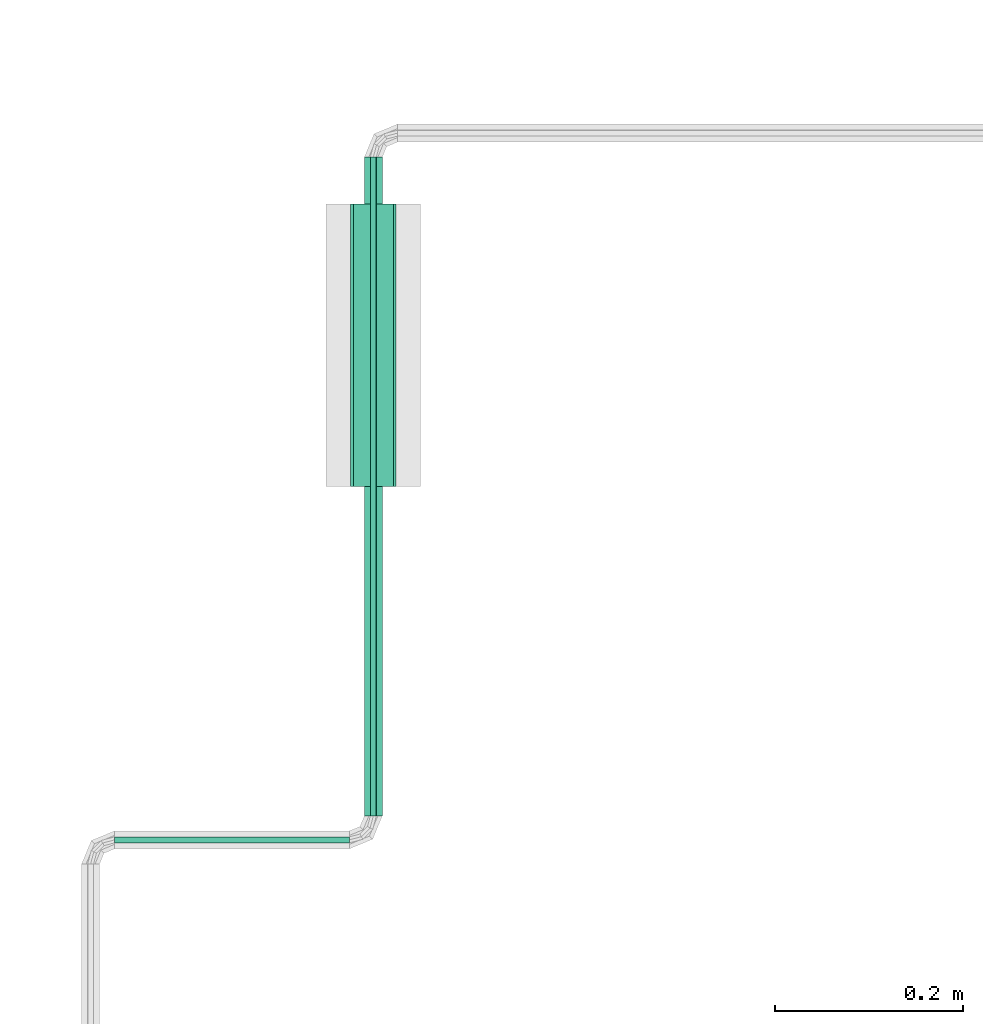
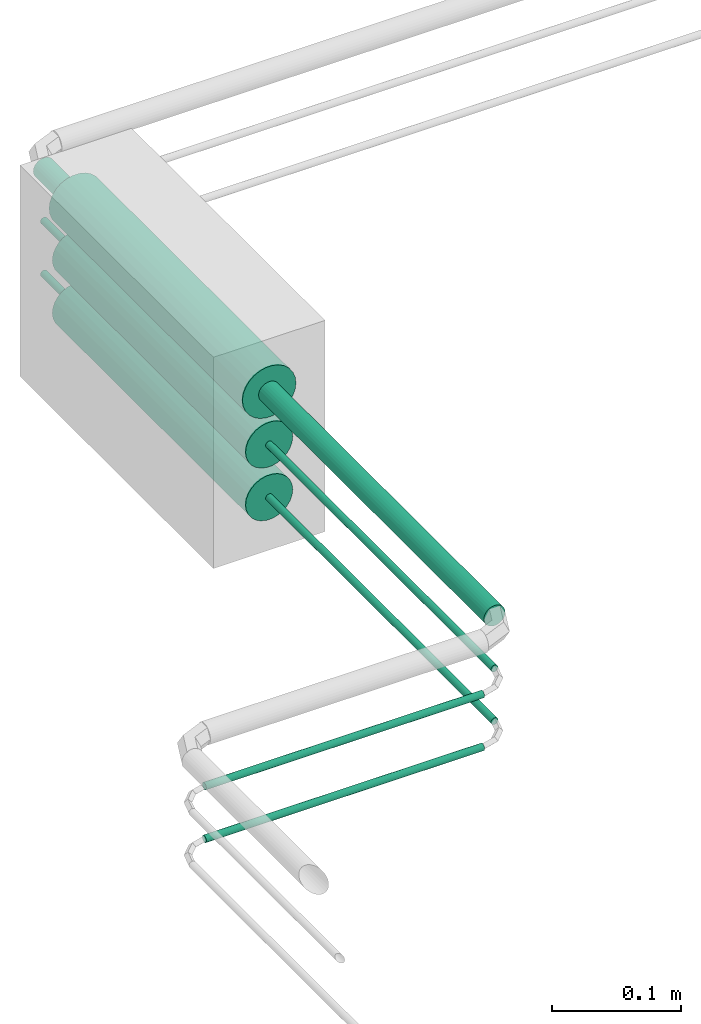
# One storey, part 17 of 45: 8 flow segments.
"""IFC2X3 building model written with IfcOpenShell, lengths in millimetres."""

from ifc_helpers import new_model, entity, si_unit, converted_unit, derived_unit, direction, frame, origin, origin_2d_with_axis, place, context, subcontext, project, spatial, circle, extrude, type_object, element, save


model = new_model("IFC2X3")

# Units and contexts
model_context = context("Model", 3, precision=0.01, world=origin(), true_north=direction((6.12303176911189e-17, 1.0)))
body_context = subcontext(model_context, "Body", "Model", "MODEL_VIEW")
ifc_project = project(units=[si_unit("LENGTHUNIT", "METRE", prefix="MILLI"), si_unit("AREAUNIT", "SQUARE_METRE"), si_unit("VOLUMEUNIT", "CUBIC_METRE"), converted_unit("PLANEANGLEUNIT", "DEGREE", entity("IfcRatioMeasure", 0.0174532925199433), si_unit("PLANEANGLEUNIT", "RADIAN"), dimensions=[0, 0, 0, 0, 0, 0, 0]), si_unit("MASSUNIT", "GRAM", prefix="KILO"), derived_unit("MASSDENSITYUNIT", [(si_unit("MASSUNIT", "GRAM", prefix="KILO"), 1), (si_unit("LENGTHUNIT", "METRE"), -3)]), derived_unit("MOMENTOFINERTIAUNIT", [(si_unit("LENGTHUNIT", "METRE"), 4)]), si_unit("TIMEUNIT", "SECOND"), si_unit("FREQUENCYUNIT", "HERTZ"), si_unit("THERMODYNAMICTEMPERATUREUNIT", "DEGREE_CELSIUS"), derived_unit("THERMALTRANSMITTANCEUNIT", [(si_unit("MASSUNIT", "GRAM", prefix="KILO"), 1), (si_unit("THERMODYNAMICTEMPERATUREUNIT", "KELVIN"), -1), (si_unit("TIMEUNIT", "SECOND"), -3)]), derived_unit("VOLUMETRICFLOWRATEUNIT", [(si_unit("LENGTHUNIT", "METRE"), 3), (si_unit("TIMEUNIT", "SECOND"), -1)]), derived_unit("MASSFLOWRATEUNIT", [(si_unit("MASSUNIT", "GRAM", prefix="KILO"), 1), (si_unit("TIMEUNIT", "SECOND"), -1)]), derived_unit("ROTATIONALFREQUENCYUNIT", [(si_unit("TIMEUNIT", "SECOND"), -1)]), si_unit("ELECTRICCURRENTUNIT", "AMPERE"), si_unit("ELECTRICVOLTAGEUNIT", "VOLT"), si_unit("POWERUNIT", "WATT"), si_unit("FORCEUNIT", "NEWTON", prefix="KILO"), si_unit("ILLUMINANCEUNIT", "LUX"), si_unit("LUMINOUSFLUXUNIT", "LUMEN"), si_unit("LUMINOUSINTENSITYUNIT", "CANDELA"), derived_unit("USERDEFINED", [(si_unit("MASSUNIT", "GRAM", prefix="KILO"), -1), (si_unit("LENGTHUNIT", "METRE"), -2), (si_unit("TIMEUNIT", "SECOND"), 3), (si_unit("LUMINOUSFLUXUNIT", "LUMEN"), 1)]), derived_unit("LINEARVELOCITYUNIT", [(si_unit("LENGTHUNIT", "METRE"), 1), (si_unit("TIMEUNIT", "SECOND"), -1)]), si_unit("PRESSUREUNIT", "PASCAL"), derived_unit("USERDEFINED", [(si_unit("LENGTHUNIT", "METRE"), -2), (si_unit("MASSUNIT", "GRAM", prefix="KILO"), 1), (si_unit("TIMEUNIT", "SECOND"), -2)]), derived_unit("LINEARFORCEUNIT", [(si_unit("MASSUNIT", "GRAM", prefix="KILO"), 1), (si_unit("LENGTHUNIT", "METRE"), 1), (si_unit("TIMEUNIT", "SECOND"), -2), (si_unit("LENGTHUNIT", "METRE"), -1)]), derived_unit("PLANARFORCEUNIT", [(si_unit("MASSUNIT", "GRAM", prefix="KILO"), 1), (si_unit("LENGTHUNIT", "METRE"), 1), (si_unit("TIMEUNIT", "SECOND"), -2), (si_unit("LENGTHUNIT", "METRE"), -2)])], contexts=[model_context])

# Site, building, storey
site_placement = place(None, frame((-24836.06, 8968.75, 0.0)))
site = spatial("IfcSite", under=ifc_project, at=site_placement, CompositionType="ELEMENT")
building_placement = place(site_placement, origin())
building = spatial("IfcBuilding", under=site, at=building_placement, CompositionType="ELEMENT")
storey_placement = place(building_placement, frame((0.0, 0.0, -4200.0)))
storey = spatial("IfcBuildingStorey", under=building, at=storey_placement, CompositionType="ELEMENT", Elevation=-4200.0)

# Flow segments
pipe_segment_type_1 = type_object("IfcPipeSegmentType", PredefinedType="NOTDEFINED")
flow_segment_1_placement = place(storey_placement, frame((67060.13, -1688.35, 2188.88)))
element("IfcFlowSegment", 1, at=flow_segment_1_placement, inside=storey, type_object=pipe_segment_type_1, context=body_context, shape_type="SweptSolid", body=[
    extrude(circle(Radius=9.525, at=origin_2d_with_axis()), frame((11.12, 0.0, 11.12), z_axis=(0.0, 1.0, 0.0), x_axis=(1.0, 0.0, 0.0)), (0.0, 0.0, 1.0), 699.200039565845),
])
flow_segment_2_placement = place(storey_placement, frame((66796.65, -1718.52, 2145.23)))
element("IfcFlowSegment", 2, at=flow_segment_2_placement, inside=storey, type_object=pipe_segment_type_1, context=body_context, shape_type="SweptSolid", body=[
    extrude(circle(Radius=3.175, at=origin_2d_with_axis()), frame((0.0, 4.77, 4.77), z_axis=(1.0, 0.0, 0.0), x_axis=(0.0, -1.0, 0.0)), (0.0, 0.0, 1.0), 249.19997588023),
])
flow_segment_3_placement = place(storey_placement, frame((67066.48, -1688.35, 2145.23)))
element("IfcFlowSegment", 3, at=flow_segment_3_placement, inside=storey, type_object=pipe_segment_type_1, context=body_context, shape_type="SweptSolid", body=[
    extrude(circle(Radius=3.175, at=origin_2d_with_axis()), frame((4.77, 0.0, 4.77), z_axis=(0.0, 1.0, 0.0), x_axis=(1.0, 0.0, 0.0)), (0.0, 0.0, 1.0), 699.200039565845),
])
flow_segment_4_placement = place(storey_placement, frame((66796.65, -1718.52, 2095.23)))
element("IfcFlowSegment", 4, at=flow_segment_4_placement, inside=storey, type_object=pipe_segment_type_1, context=body_context, shape_type="SweptSolid", body=[
    extrude(circle(Radius=3.175, at=origin_2d_with_axis()), frame((0.0, 4.77, 4.77), z_axis=(1.0, 0.0, 0.0), x_axis=(0.0, -1.0, 0.0)), (0.0, 0.0, 1.0), 249.19997588023),
])
flow_segment_5_placement = place(storey_placement, frame((67066.48, -1688.35, 2095.23)))
element("IfcFlowSegment", 5, at=flow_segment_5_placement, inside=storey, type_object=pipe_segment_type_1, context=body_context, shape_type="SweptSolid", body=[
    extrude(circle(Radius=3.175, at=origin_2d_with_axis()), frame((4.77, 0.0, 4.77), z_axis=(0.0, 1.0, 0.0), x_axis=(1.0, 0.0, 0.0)), (0.0, 0.0, 1.0), 699.200039565845),
])
pipe_segment_type_2 = type_object("IfcPipeSegmentType", PredefinedType="NOTDEFINED")
flow_segment_6_placement = place(storey_placement, frame((67045.65, -1338.75, 2174.4)))
element("IfcFlowSegment", 6, at=flow_segment_6_placement, inside=storey, type_object=pipe_segment_type_2, context=body_context, shape_type="SweptSolid", body=[
    extrude(circle(Radius=24.0, at=origin_2d_with_axis()), frame((25.6, 0.0, 25.6), z_axis=(0.0, 1.0, 0.0), x_axis=(-1.0, 0.0, 0.0)), (0.0, 0.0, 1.0), 299.999977050059),
])
for number, where in (
    (7, (67048.5, -1338.75, 2127.25)),
    (8, (67048.5, -1338.75, 2077.25)),
):
    element("IfcFlowSegment", number, at=place(storey_placement, frame(where)), inside=storey, type_object=pipe_segment_type_2, context=body_context, shape_type="SweptSolid", body=[
        extrude(circle(Radius=21.15, at=origin_2d_with_axis()), frame((22.75, 0.0, 22.75), z_axis=(0.0, 1.0, 0.0), x_axis=(-1.0, 0.0, 0.0)), (0.0, 0.0, 1.0), 299.99997705006),
    ])

save(model, "model.ifc")
